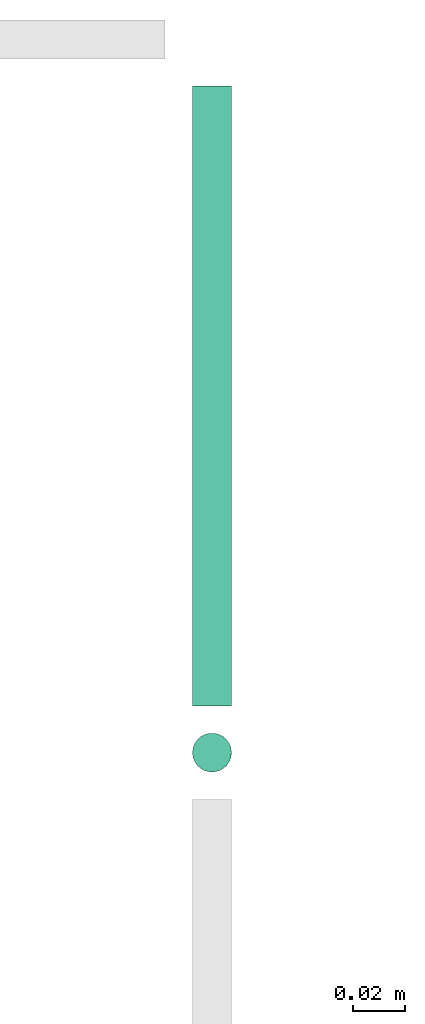
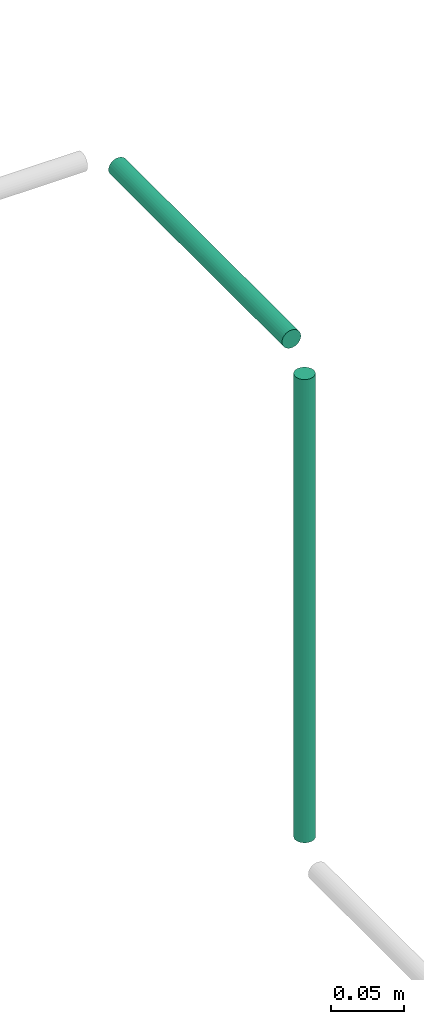
# One storey, part 48 of 65: 2 flow segments.
"""IFC2X3 building model written with IfcOpenShell, lengths in millimetres."""

from ifc_helpers import new_model, entity, si_unit, converted_unit, derived_unit, direction, frame, frame_2d, origin, origin_2d_with_axis, place, context, subcontext, project, spatial, circle, extrude, type_object, element, save


model = new_model("IFC2X3")

# Units and contexts
model_context = context("Model", 3, precision=0.01, world=origin(), true_north=direction((6.12303176911189e-17, 1.0)))
body_context = subcontext(model_context, "Body", "Model", "MODEL_VIEW")
ifc_project = project(units=[si_unit("LENGTHUNIT", "METRE", prefix="MILLI"), si_unit("AREAUNIT", "SQUARE_METRE"), si_unit("VOLUMEUNIT", "CUBIC_METRE"), converted_unit("PLANEANGLEUNIT", "DEGREE", entity("IfcRatioMeasure", 0.0174532925199433), si_unit("PLANEANGLEUNIT", "RADIAN"), dimensions=[0, 0, 0, 0, 0, 0, 0]), si_unit("MASSUNIT", "GRAM", prefix="KILO"), derived_unit("MASSDENSITYUNIT", [(si_unit("MASSUNIT", "GRAM", prefix="KILO"), 1), (si_unit("LENGTHUNIT", "METRE"), -3)]), derived_unit("MOMENTOFINERTIAUNIT", [(si_unit("LENGTHUNIT", "METRE"), 4)]), si_unit("TIMEUNIT", "SECOND"), si_unit("FREQUENCYUNIT", "HERTZ"), si_unit("THERMODYNAMICTEMPERATUREUNIT", "DEGREE_CELSIUS"), derived_unit("THERMALTRANSMITTANCEUNIT", [(si_unit("MASSUNIT", "GRAM", prefix="KILO"), 1), (si_unit("THERMODYNAMICTEMPERATUREUNIT", "KELVIN"), -1), (si_unit("TIMEUNIT", "SECOND"), -3)]), derived_unit("VOLUMETRICFLOWRATEUNIT", [(si_unit("LENGTHUNIT", "METRE"), 3), (si_unit("TIMEUNIT", "SECOND"), -1)]), derived_unit("MASSFLOWRATEUNIT", [(si_unit("MASSUNIT", "GRAM", prefix="KILO"), 1), (si_unit("TIMEUNIT", "SECOND"), -1)]), derived_unit("ROTATIONALFREQUENCYUNIT", [(si_unit("TIMEUNIT", "SECOND"), -1)]), si_unit("ELECTRICCURRENTUNIT", "AMPERE"), si_unit("ELECTRICVOLTAGEUNIT", "VOLT"), si_unit("POWERUNIT", "WATT"), si_unit("FORCEUNIT", "NEWTON", prefix="KILO"), si_unit("ILLUMINANCEUNIT", "LUX"), si_unit("LUMINOUSFLUXUNIT", "LUMEN"), si_unit("LUMINOUSINTENSITYUNIT", "CANDELA"), derived_unit("USERDEFINED", [(si_unit("MASSUNIT", "GRAM", prefix="KILO"), -1), (si_unit("LENGTHUNIT", "METRE"), -2), (si_unit("TIMEUNIT", "SECOND"), 3), (si_unit("LUMINOUSFLUXUNIT", "LUMEN"), 1)]), derived_unit("LINEARVELOCITYUNIT", [(si_unit("LENGTHUNIT", "METRE"), 1), (si_unit("TIMEUNIT", "SECOND"), -1)]), si_unit("PRESSUREUNIT", "PASCAL"), derived_unit("USERDEFINED", [(si_unit("LENGTHUNIT", "METRE"), -2), (si_unit("MASSUNIT", "GRAM", prefix="KILO"), 1), (si_unit("TIMEUNIT", "SECOND"), -2)]), derived_unit("LINEARFORCEUNIT", [(si_unit("MASSUNIT", "GRAM", prefix="KILO"), 1), (si_unit("LENGTHUNIT", "METRE"), 1), (si_unit("TIMEUNIT", "SECOND"), -2), (si_unit("LENGTHUNIT", "METRE"), -1)]), derived_unit("PLANARFORCEUNIT", [(si_unit("MASSUNIT", "GRAM", prefix="KILO"), 1), (si_unit("LENGTHUNIT", "METRE"), 1), (si_unit("TIMEUNIT", "SECOND"), -2), (si_unit("LENGTHUNIT", "METRE"), -2)])], contexts=[model_context])

# Site, building, storey
site_placement = place(None, frame((0.0, -0.00077364408347762, 0.0)))
site = spatial("IfcSite", under=ifc_project, at=site_placement, CompositionType="ELEMENT")
building_placement = place(site_placement, origin())
building = spatial("IfcBuilding", under=site, at=building_placement, CompositionType="ELEMENT")
storey_placement = place(building_placement, frame((0.0, 0.0, 19800.0)))
storey = spatial("IfcBuildingStorey", under=building, at=storey_placement, CompositionType="ELEMENT", Elevation=19800.0)

# Flow segments
pipe_segment_type = type_object("IfcPipeSegmentType", PredefinedType="NOTDEFINED")
flow_segment_1_placement = place(storey_placement, frame((49085.8646025567, 18091.31614154, 2642.99928834774)))
element("IfcFlowSegment", 1, at=flow_segment_1_placement, inside=storey, type_object=pipe_segment_type, context=body_context, shape_type="SweptSolid", body=[
    extrude(circle(Radius=7.5, at=frame_2d((0.0, -2.16573425859679e-12), x_axis=(1.0, 0.0))), frame((9.13217861315134, 9.09527223591853, 0.000711563191839559), z_axis=(-9.48750920652737e-05, 0.0, 0.999999995499358), x_axis=(0.999999995499358, 0.0, 9.48750920652737e-05)), (0.0, 0.0, 1.0), 389.00000183982),
])
flow_segment_2_placement = place(storey_placement, frame((49085.8646025229, 18118.4114137759, 3040.90472776409)))
element("IfcFlowSegment", 2, at=flow_segment_2_placement, inside=storey, type_object=pipe_segment_type, context=body_context, shape_type="SweptSolid", body=[
    extrude(circle(Radius=7.5, at=origin_2d_with_axis()), frame((9.09527223591419, 0.0, 9.09527223591419), z_axis=(0.0, 1.0, 0.0), x_axis=(-1.0, 0.0, 0.0)), (0.0, 0.0, 1.0), 238.588586224207),
])

save(model, "model.ifc")
